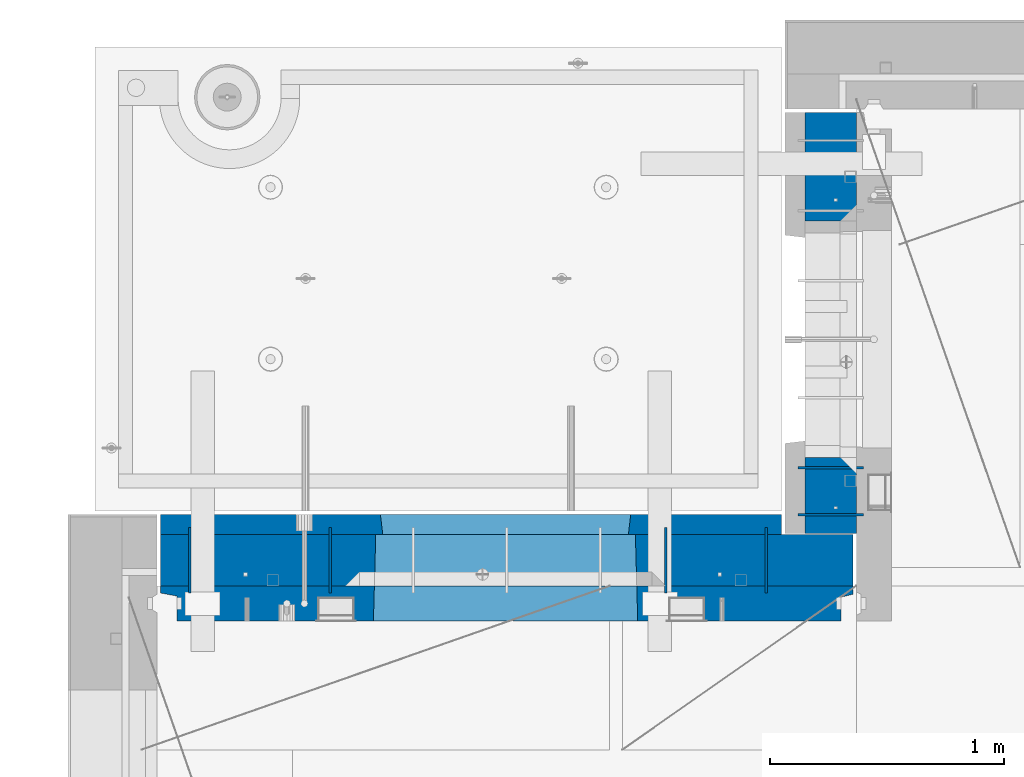
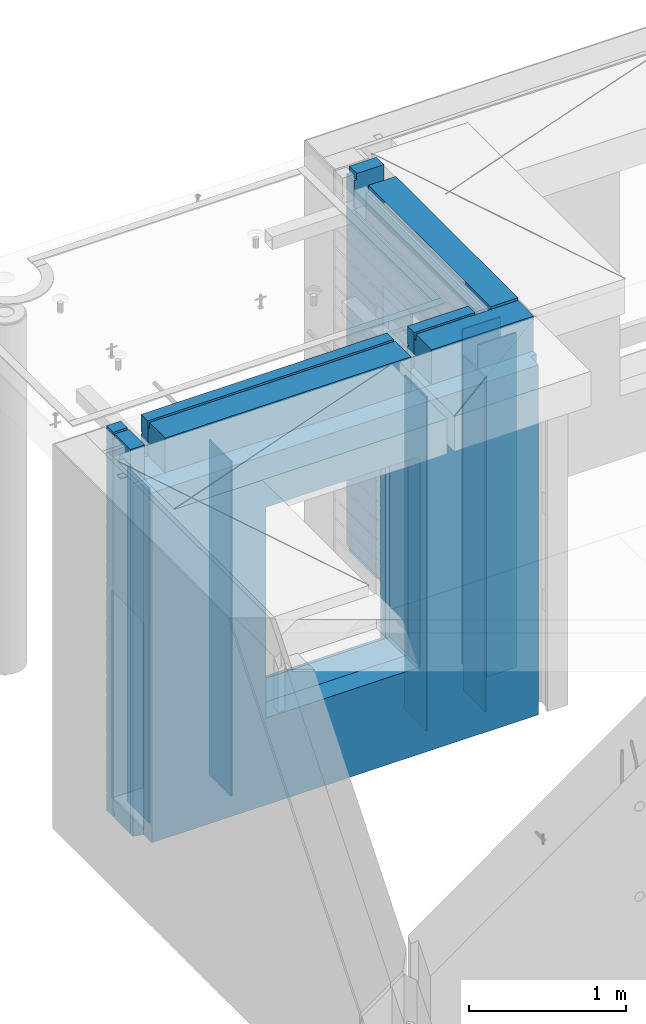
# One storey, part 227 of 341: 10 walls, 2 elements without a shape of their own.
"""IFC2X3 building model written with IfcOpenShell, lengths in millimetres."""

from ifc_helpers import new_model, si_unit, frame, origin_with_axes, place, context, subcontext, project, spatial, faceted_brep, material, type_object, element, aggregate, save


model = new_model("IFC2X3")

# Units and contexts
model_context = context("Model", 3, precision=1e-05, world=origin_with_axes())
body_context = subcontext(model_context, "Body", "Model", "MODEL_VIEW")
ifc_project = project(units=[si_unit("LENGTHUNIT", "METRE", prefix="MILLI"), si_unit("AREAUNIT", "SQUARE_METRE"), si_unit("VOLUMEUNIT", "CUBIC_METRE"), si_unit("MASSUNIT", "GRAM", prefix="KILO"), si_unit("TIMEUNIT", "SECOND"), si_unit("PLANEANGLEUNIT", "RADIAN"), si_unit("SOLIDANGLEUNIT", "STERADIAN"), si_unit("THERMODYNAMICTEMPERATUREUNIT", "DEGREE_CELSIUS"), si_unit("LUMINOUSINTENSITYUNIT", "LUMEN")], contexts=[model_context])

# Site, building, storey
site_placement = place(None, origin_with_axes())
site = spatial("IfcSite", under=ifc_project, at=site_placement, CompositionType="ELEMENT")
building_placement = place(site_placement, origin_with_axes())
building = spatial("IfcBuilding", under=site, at=building_placement, CompositionType="ELEMENT")
storey_placement = place(building_placement, origin_with_axes())
storey = spatial("IfcBuildingStorey", under=building, at=storey_placement, Name="5", CompositionType="ELEMENT", Elevation=0.0)

# Assembly, wall
assembly_1_placement = place(storey_placement, origin_with_axes())
assembly_1 = element("IfcElementAssembly", 1, at=assembly_1_placement, inside=storey, AssemblyPlace="NOTDEFINED", PredefinedType="REINFORCEMENT_UNIT")
ifc_material_1 = material(Name="Undefined")
wall_type_1 = type_object("IfcWallType", PredefinedType="NOTDEFINED")
wall_1_placement = place(assembly_1_placement, frame((10605.0002441406, 20549.9951872276, 95115.0), z_axis=(0.0, 0.0, 1.0), x_axis=(0.0, 1.0, 0.0)))
wall_1 = element("IfcWall", 2, at=wall_1_placement, type_object=wall_type_1, material=ifc_material_1, Name="(PD)", context=body_context, shape_type="Brep", body=[
    faceted_brep([(0.0, 5.0, -1300.0), (0.0, 5.0, 1300.0), (280.0, 5.0, 1300.0), (280.0, 5.0, -1300.0), (0.0, -5.0, 1300.0), (280.0, -5.0, 1300.0), (0.0, -5.0, -1300.0), (280.0, -5.0, -1300.0)], [[[0, 1, 2, 3]], [[1, 4, 5, 2]], [[4, 6, 7, 5]], [[6, 0, 3, 7]], [[5, 7, 3, 2]], [[6, 4, 1, 0]]]),
])

assembly_2_placement = place(storey_placement, origin_with_axes())
assembly_2 = element("IfcElementAssembly", 3, at=assembly_2_placement, inside=storey, AssemblyPlace="NOTDEFINED", PredefinedType="REINFORCEMENT_UNIT")
wall_2_placement = place(assembly_2_placement, frame((11020.0, 20885.0002441406, 95115.0), z_axis=(0.0, 0.0, 1.0), x_axis=(-1.0, 3.00000001838171e-08, 0.0)))
wall_2 = element("IfcWall", 4, at=wall_2_placement, type_object=wall_type_1, material=ifc_material_1, Name="(PD)", context=body_context, shape_type="Brep", body=[
    faceted_brep([(0.0, 5.0, -1300.0), (0.0, 5.0, 1300.0), (280.0, 5.0, 1300.0), (280.0, 5.0, -1300.0), (0.0, -5.0, 1300.0), (280.0, -5.0, 1300.0), (0.0, -5.0, -1300.0), (280.0, -5.0, -1300.0)], [[[0, 1, 2, 3]], [[1, 4, 5, 2]], [[4, 6, 7, 5]], [[6, 0, 3, 7]], [[5, 7, 3, 2]], [[6, 4, 1, 0]]]),
])

# Wall
wall_3_placement = place(assembly_1_placement, frame((8140.00024414063, 20549.9951872276, 95115.0), z_axis=(0.0, 0.0, 1.0), x_axis=(0.0, 1.0, 0.0)))
wall_3 = element("IfcWall", 5, at=wall_3_placement, type_object=wall_type_1, material=ifc_material_1, Name="(PD)", context=body_context, shape_type="Brep", body=[
    faceted_brep([(0.0, 5.0, -1300.0), (0.0, 5.0, 1300.0), (280.0, 5.0, 1300.0), (280.0, 5.0, -1300.0), (0.0, -5.0, 1300.0), (280.0, -5.0, 1300.0), (0.0, -5.0, -1300.0), (280.0, -5.0, -1300.0)], [[[0, 1, 2, 3]], [[1, 4, 5, 2]], [[4, 6, 7, 5]], [[6, 0, 3, 7]], [[5, 7, 3, 2]], [[6, 4, 1, 0]]]),
])

wall_4_placement = place(assembly_1_placement, frame((8740.00024414063, 20549.9951872276, 95115.0), z_axis=(0.0, 0.0, 1.0), x_axis=(0.0, 1.0, 0.0)))
wall_4 = element("IfcWall", 6, at=wall_4_placement, type_object=wall_type_1, material=ifc_material_1, Name="(PD)", context=body_context, shape_type="Brep", body=[
    faceted_brep([(0.0, 5.0, -1300.0), (0.0, 5.0, 1300.0), (280.0, 5.0, 1300.0), (280.0, 5.0, -1300.0), (0.0, -5.0, 1300.0), (280.0, -5.0, 1300.0), (0.0, -5.0, -1300.0), (280.0, -5.0, -1300.0)], [[[0, 1, 2, 3]], [[1, 4, 5, 2]], [[4, 6, 7, 5]], [[6, 0, 3, 7]], [[5, 7, 3, 2]], [[6, 4, 1, 0]]]),
])

wall_5_placement = place(assembly_1_placement, frame((10175.0002441406, 20549.9951872276, 95115.0), z_axis=(0.0, 0.0, 1.0), x_axis=(0.0, 1.0, 0.0)))
wall_5 = element("IfcWall", 7, at=wall_5_placement, type_object=wall_type_1, material=ifc_material_1, Name="(PD)", context=body_context, shape_type="Brep", body=[
    faceted_brep([(0.0, 5.0, -1300.0), (0.0, 5.0, 1300.0), (280.0, 5.0, 1300.0), (280.0, 5.0, -1300.0), (0.0, -5.0, 1300.0), (280.0, -5.0, 1300.0), (0.0, -5.0, -1300.0), (280.0, -5.0, -1300.0)], [[[0, 1, 2, 3]], [[1, 4, 5, 2]], [[4, 6, 7, 5]], [[6, 0, 3, 7]], [[5, 7, 3, 2]], [[6, 4, 1, 0]]]),
])

wall_6_placement = place(assembly_2_placement, frame((11020.0, 21085.0002441406, 95115.0), z_axis=(0.0, 0.0, 1.0), x_axis=(-1.0, 3.00000001838171e-08, 0.0)))
wall_6 = element("IfcWall", 8, at=wall_6_placement, type_object=wall_type_1, material=ifc_material_1, Name="(PD)", context=body_context, shape_type="Brep", body=[
    faceted_brep([(0.0, 5.0, -1300.0), (0.0, 5.0, 1300.0), (280.0, 5.0, 1300.0), (280.0, 5.0, -1300.0), (0.0, -5.0, 1300.0), (280.0, -5.0, 1300.0), (0.0, -5.0, -1300.0), (280.0, -5.0, -1300.0)], [[[0, 1, 2, 3]], [[1, 4, 5, 2]], [[4, 6, 7, 5]], [[6, 0, 3, 7]], [[5, 7, 3, 2]], [[6, 4, 1, 0]]]),
])

ifc_material_2 = material(Name="COS5gt")
wall_type_2 = type_object("IfcWallType", PredefinedType="NOTDEFINED")
wall_7_placement = place(assembly_1_placement, frame((8000.0, 20689.9951872276, 95247.5), z_axis=(0.0, 0.0, 1.0), x_axis=(1.0, 0.0, 0.0)))
wall_7 = element("IfcWall", 9, at=wall_7_placement, type_object=wall_type_2, material=ifc_material_2, context=body_context, shape_type="Brep", body=[
    faceted_brep([(15.0, 110.0, 1442.5), (15.0, 90.0, 1442.5), (119.999999999998, 90.0, 1442.5), (119.999999999998, 110.0, 1442.5), (15.0, 90.0, 1492.5), (119.999999999998, 90.0, 1492.5), (15.0, -110.0, 1492.5), (119.999999999998, -110.0, 1492.5), (119.999999999998, -110.0, 1222.5), (119.999999999998, 110.0, 1222.5), (269.999999999998, -110.0, 1222.5), (269.999999999998, 110.0, 1222.5), (269.999999999998, 110.0, 1442.5), (269.999999999998, 90.0, 1442.5), (2075.0, 90.0, 1442.5), (2075.0, 110.0, 1442.5), (269.999999999998, 90.0, 1492.5), (2075.0, 90.0, 1492.5), (269.999999999998, -110.0, 1492.5), (2075.0, -110.0, 1492.5), (2075.0, -110.000000000004, 1222.5), (2075.0, 109.999999999996, 1222.5), (2225.0, -110.000000000004, 1222.5), (2225.0, 109.999999999996, 1222.5), (2975.0, -110.0, 1492.5), (2975.0, 90.0, 1492.5), (2225.0, 90.0, 1492.5), (2225.0, -110.0, 1492.5), (2975.0, -110.0, -1492.5), (15.0, -110.0, -1492.5), (15.0, 90.0, -1492.5), (2975.0, 90.0, -1492.5), (2975.0, 110.0, 1442.5), (2975.0, 90.0, 1442.5), (2975.0, 90.0, -1442.5), (2975.0, 110.0, -1442.5), (2225.0, 110.0, 1442.5), (2225.0, 90.0, 1442.5), (929.055290664681, -110.000000000004, -813.445945945947), (929.055290664681, -110.000000000004, 813.445945945947), (2050.94718255657, -110.000000000004, 813.445945945947), (2050.94718255657, -110.000000000004, -813.445945945947), (935.001236610628, 110.0, -802.5), (935.001236610628, 110.0, 807.5), (935.001236610628, 110.0, -807.5), (2045.00123661063, 110.0, -807.5), (2015.00123661063, 110.0, -807.5), (965.001236610628, 110.0, -807.5), (2045.00123661063, 110.0, 807.5), (2045.00123661063, 110.0, -802.5), (15.0, 110.0, -1442.5), (15.0, 90.0, -1442.5)], [[[0, 1, 2, 3]], [[1, 4, 5, 2]], [[4, 6, 7, 5]], [[3, 2, 5, 7, 8, 9]], [[9, 8, 10, 11]], [[12, 13, 14, 15]], [[13, 16, 17, 14]], [[12, 11, 10, 18, 16, 13]], [[16, 18, 19, 17]], [[15, 14, 17, 19, 20, 21]], [[21, 20, 22, 23]], [[24, 25, 26, 27]], [[28, 29, 30, 31]], [[32, 33, 25, 24, 28, 31, 34, 35]], [[33, 32, 36, 37]], [[25, 33, 37, 26]], [[36, 23, 22, 27, 26, 37]], [[20, 19, 18, 10, 8, 7, 6, 29, 28, 24, 27, 22], [38, 39, 40, 41]], [[42, 43, 39, 38, 44]], [[41, 45, 46, 47, 44, 38]], [[40, 48, 49, 45, 41]], [[39, 43, 48, 40]], [[32, 35, 50, 0, 3, 9, 11, 12, 15, 21, 23, 36], [42, 44, 47, 46, 45, 49, 48, 43]], [[30, 29, 6, 4, 1, 0, 50, 51]], [[35, 34, 51, 50]], [[31, 30, 51, 34]]]),
])

wall_8_placement = place(assembly_2_placement, frame((10880.0, 20805.0, 95247.5), z_axis=(0.0, 0.0, 1.0), x_axis=(0.0, 1.0, 0.0)))
wall_8 = element("IfcWall", 10, at=wall_8_placement, type_object=wall_type_2, material=ifc_material_2, context=body_context, shape_type="Brep", body=[
    faceted_brep([(1800.0, -110.0, 1492.5), (1800.0, 90.0, 1492.5), (1705.0, 90.0, 1492.5), (1705.0, -110.0, 1492.5), (1800.0, 90.0, 1442.5), (1800.0, 110.0, 1442.5), (1705.0, 110.0, 1442.5), (1705.0, 90.0, 1442.5), (0.0, 110.0, 1442.5), (0.0, 90.0, 1442.5), (1555.0, 90.0, 1442.5), (1555.0, 110.0, 1442.5), (0.0, -110.0, -1492.5), (0.0, 90.0, -1492.5), (325.000271651108, 90.0, -1492.5), (325.000271651108, -110.0, -1492.5), (0.0, 90.0, -1442.5), (325.000271651108, 90.0, -1442.5), (0.0, -110.0, 1492.5), (0.0, 90.0, 1492.5), (0.0, 110.0, -1442.5), (325.000271651108, 110.0, -1442.5), (325.000271651108, 110.0, 857.5), (325.000271651108, -110.0, 857.5), (1335.00027165111, 110.0, 857.5), (1335.00027165111, -110.0, 857.5), (1555.0, 110.0, 1222.5), (1705.0, 110.0, 1222.5), (1800.0, 110.0, -1442.5), (1335.00027165111, 110.0, -1442.5), (1800.0, 90.0, -1442.5), (1800.0, 90.0, -1492.5), (1335.00027165111, 90.0, -1492.5), (1335.00027165111, 90.0, -1442.5), (1800.0, -110.0, -1492.5), (1335.00027165111, -110.0, -1492.5), (1705.0, -110.0, 1222.5), (1555.0, -110.0, 1222.5), (1555.0, -110.0, 1492.5), (1555.0, 90.0, 1492.5)], [[[0, 1, 2, 3]], [[4, 5, 6, 7]], [[8, 9, 10, 11]], [[12, 13, 14, 15]], [[13, 16, 17, 14]], [[13, 12, 18, 19, 9, 8, 20, 16]], [[16, 20, 21, 17]], [[15, 14, 17, 21, 22, 23]], [[23, 22, 24, 25]], [[21, 20, 8, 11, 26, 27, 6, 5, 28, 29, 24, 22]], [[30, 31, 32, 33]], [[28, 30, 33, 29]], [[5, 4, 1, 0, 34, 31, 30, 28]], [[31, 34, 35, 32]], [[25, 24, 29, 33, 32, 35]], [[34, 0, 3, 36, 37, 38, 18, 12, 15, 23, 25, 35]], [[19, 18, 38, 39]], [[9, 19, 39, 10]], [[38, 37, 26, 11, 10, 39]], [[36, 27, 26, 37]], [[3, 2, 7, 6, 27, 36]], [[1, 4, 7, 2]]]),
])

aggregate(assembly_2, [wall_2, wall_6, wall_8])

ifc_material_3 = material(Name="CONCRETE/C30/37")
wall_type_3 = type_object("IfcWallType", PredefinedType="NOTDEFINED")
wall_9_placement = place(assembly_1_placement, frame((8000.0, 20842.4951872276, 95247.5), z_axis=(0.0, 0.0, 1.0), x_axis=(1.0, 0.0, 0.0)))
wall_9 = element("IfcWall", 11, at=wall_9_placement, type_object=wall_type_3, material=ifc_material_3, context=body_context, shape_type="Brep", body=[
    faceted_brep([(2670.0, -42.5, 1492.5), (2670.0, 42.5, 1492.5), (2225.0, 42.5, 1492.5), (2225.0, -42.5, 1492.5), (2670.0, 42.4999992431622, 1356.99999988925), (2225.0, 42.4999993700148, 1356.99999988925), (2670.0, 32.4999991126933, 1355.00000040043), (2670.0, 32.4999992506928, 1344.9999999992), (2225.0, 32.4999992506928, 1344.9999999992), (2225.0, 32.4999991126933, 1355.00000040043), (2670.0, 42.4999996036859, 1342.99999994476), (2225.0, 42.4999996701117, 1342.99999994476), (2670.0, 42.4999993831079, 892.999999944761), (15.0, 42.5, 892.999999944761), (15.0, 32.4999992506928, 894.9999999992), (2670.0, 32.4999992506928, 894.9999999992), (15.0, 32.4999991126933, 905.000000400425), (2670.0, 32.4999991126933, 905.000000400425), (2670.0, 42.4999992431622, 906.999999889245), (15.0, 42.5, 906.999999889245), (15.0, 42.5, 1042.99999994476), (2670.0, 42.4999994189602, 1042.99999994476), (15.0, 32.4999992506928, 1044.9999999992), (2670.0, 32.4999992506928, 1044.9999999992), (15.0, 32.4999991126933, 1055.00000040043), (2670.0, 32.4999991126933, 1055.00000040043), (2670.0, 42.4999992431622, 1056.99999988925), (15.0, 42.5, 1056.99999988925), (15.0, 42.5, 1192.99999994476), (2670.0, 42.4999994795107, 1192.99999994476), (15.0000000000009, 32.4999992506928, 1194.9999999992), (2670.0, 32.4999992506928, 1194.9999999992), (15.0000000000009, 32.4999991126933, 1205.00000040043), (2670.0, 32.4999991126933, 1205.00000040043), (2670.0, 42.4999992431622, 1206.99999988925), (15.0, 42.5, 1206.99999988925), (15.0, 32.4999992506928, 1344.9999999992), (15.0, 32.4999991126933, 1355.00000040043), (119.999999999998, 32.4999991126933, 1355.00000040043), (119.999999999998, 32.4999992506928, 1344.9999999992), (15.0, 42.5, 1342.99999994476), (119.999999999998, 42.4999999843276, 1342.99999994476), (269.999999999998, 32.4999992506928, 1344.9999999992), (269.999999999998, 32.4999991126933, 1355.00000040043), (2075.0, 32.4999991126933, 1355.00000040043), (2075.0, 32.4999992506928, 1344.9999999992), (269.999999999998, 42.4999999619358, 1342.99999994476), (2075.0, 42.4999996925035, 1342.99999994476), (119.999999999998, 42.4999999076099, 1222.5), (269.999999999998, 42.4999998750354, 1222.5), (2075.0, 42.4999994593163, 1222.5), (2225.0, 42.4999994264763, 1222.5), (119.999999999998, -42.5, 1222.5), (269.999999999998, -42.5, 1222.5), (269.999999999998, 42.5, 1492.5), (269.999999999998, 42.4999999273095, 1356.99999988925), (269.999999999998, -42.5, 1492.5), (2075.0, -42.5, 1492.5), (2075.0, 42.5, 1492.5), (2075.0, 42.4999994127757, 1356.99999988925), (2075.0, -42.5000000000036, 1222.5), (2225.0, -42.5000000000036, 1222.5), (2670.0, -42.5, -1492.5), (2670.0, 42.5, -1492.5), (2670.0, 42.5, -1357.00000005524), (2670.0, 32.4999992506928, -1355.0000000008), (2670.0, 32.4999991126933, -1344.99999959957), (2670.0, 42.4999992431622, -1343.00000011075), (2670.0, 42.4999992794619, -1207.00000005524), (2670.0, 32.4999992506928, -1205.0000000008), (2670.0, 32.4999991126933, -1194.99999959957), (2670.0, 42.4999992431622, -1193.00000011075), (2670.0, 42.4999992814919, -1057.00000005524), (2670.0, 32.4999992506928, -1055.0000000008), (2670.0, 32.4999991126933, -1044.99999959957), (2670.0, 42.4999992431622, -1043.00000011075), (2670.0, 42.4999992837584, -907.000000055239), (2670.0, 32.4999992506928, -905.0000000008), (2670.0, 32.4999991126933, -894.999999599575), (2670.0, 42.4999992431622, -893.000000110755), (2670.0, 42.4999992863086, -757.000000055239), (2670.0, 32.4999992506928, -755.0000000008), (2670.0, 32.4999991126933, -744.999999599575), (2670.0, 42.4999992431622, -743.000000110755), (2670.0, 42.4999992892044, -607.000000055239), (2670.0, 32.4999992506928, -605.0000000008), (2670.0, 32.4999991126933, -594.999999599575), (2670.0, 42.4999992431622, -593.000000110755), (2670.0, 42.4999992925186, -457.000000055239), (2670.0, 32.4999992506928, -455.0000000008), (2670.0, 32.4999991126933, -444.999999599575), (2670.0, 42.4999992431622, -443.000000110755), (2670.0, 42.4999992963421, -307.000000055239), (2670.0, 32.4999992506928, -305.0000000008), (2670.0, 32.4999991126933, -294.999999599575), (2670.0, 42.4999992431622, -293.000000110755), (2670.0, 42.4999993008096, -157.000000055239), (2670.0, 32.4999992506928, -155.0000000008), (2670.0, 32.4999991126933, -144.999999599575), (2670.0, 42.4999992431622, -143.000000110755), (2670.0, 42.4999993060956, -7.00000005523907), (2670.0, 32.4999992506928, -5.00000000080036), (2670.0, 32.4999991126933, 5.00000040042505), (2670.0, 42.4999992431622, 6.99999988924537), (2670.0, 42.4999993124511, 142.999999944761), (2670.0, 32.4999992506928, 144.9999999992), (2670.0, 32.4999991126933, 155.000000400425), (2670.0, 42.4999992431622, 156.999999889245), (2670.0, 42.4999993202327, 292.999999944761), (2670.0, 32.4999992506928, 294.9999999992), (2670.0, 32.4999991126933, 305.000000400425), (2670.0, 42.4999992431622, 306.999999889245), (2670.0, 42.4999993299862, 442.999999944761), (2670.0, 32.4999992506928, 444.9999999992), (2670.0, 32.4999991126933, 455.000000400425), (2670.0, 42.4999992431622, 456.999999889245), (2670.0, 42.4999993425627, 592.999999944761), (2670.0, 32.4999992506928, 594.9999999992), (2670.0, 32.4999991126933, 605.000000400425), (2670.0, 42.4999992431622, 606.999999889245), (2670.0, 42.4999993594029, 742.999999944761), (2670.0, 32.4999992506928, 744.9999999992), (2670.0, 32.4999991126933, 755.000000400425), (2670.0, 42.4999992431622, 756.999999889245), (15.0, -42.5, -1492.5), (15.0, 42.5, -1492.5), (15.0, 42.5, -1357.00000005524), (15.0, 32.4999992506928, -1355.0000000008), (15.0, 32.4999991126933, -1344.99999959957), (15.0, 42.5, -1343.00000011075), (15.0, 42.5, -1207.00000005524), (15.0, 32.4999992506928, -1205.0000000008), (15.0, 32.4999991126933, -1194.99999959957), (15.0, 42.5, -1193.00000011075), (15.0, 42.5, -1057.00000005524), (15.0, 32.4999992506928, -1055.0000000008), (15.0, 32.4999991126933, -1044.99999959957), (15.0, 42.5, -1043.00000011075), (15.0, 42.5, -907.000000055239), (15.0000000000009, 32.4999992506928, -905.0000000008), (15.0000000000009, 32.4999991126933, -894.999999599575), (15.0, 42.5, -893.000000110755), (15.0, 32.4999991126933, 755.000000400425), (15.0, 42.5, 756.999999889245), (955.001236610628, 42.499999732041, 756.999999889245), (956.177707303252, 32.4999991126933, 755.000000400425), (15.0, 32.4999992506928, 744.9999999992), (956.177707287017, 32.4999992506928, 744.9999999992), (15.0, 42.5, 742.999999944761), (955.001236610628, 42.4999997731975, 742.999999944761), (15.0, 42.5, 606.999999889245), (955.001236610628, 42.499999732041, 606.999999889245), (15.0, 32.4999991126933, 605.000000400425), (956.177707303252, 32.4999991126933, 605.000000400425), (15.0, 32.4999992506928, 594.9999999992), (956.177707287017, 32.4999992506928, 594.9999999992), (15.0, 42.5, 592.999999944761), (955.001236610628, 42.4999997672348, 592.999999944761), (15.0, 42.5, 456.999999889245), (955.001236610628, 42.499999732041, 456.999999889245), (15.0, 32.4999991126933, 455.000000400425), (956.177707303252, 32.4999991126933, 455.000000400425), (15.0, 32.4999992506928, 444.9999999992), (956.177707287017, 32.4999992506928, 444.9999999992), (15.0, 42.5, 442.999999944761), (955.001236610628, 42.499999762782, 442.999999944761), (15.0, 42.5, 306.999999889245), (955.001236610628, 42.499999732041, 306.999999889245), (15.0, 32.4999991126933, 305.000000400425), (956.177707303252, 32.4999991126933, 305.000000400425), (15.0, 32.4999992506928, 294.9999999992), (956.177707287017, 32.4999992506928, 294.9999999992), (15.0, 42.5, 292.999999944761), (955.001236610628, 42.4999997593295, 292.999999944761), (15.0, 42.5, 156.999999889245), (955.001236610628, 42.499999732041, 156.999999889245), (15.0000000000009, 32.4999991126933, 155.000000400425), (956.177707303254, 32.4999991126933, 155.000000400425), (15.0000000000009, 32.4999992506928, 144.9999999992), (956.177707287017, 32.4999992506928, 144.9999999992), (15.0, 42.5, 142.999999944761), (955.001236610628, 42.4999997565719, 142.999999944761), (15.0, 42.5, 6.99999988924537), (955.001236610628, 42.499999732041, 6.99999988924537), (14.9999999999991, 32.4999991126933, 5.00000040042505), (956.177707303254, 32.4999991126933, 5.00000040042505), (14.9999999999991, 32.4999992506928, -5.00000000080036), (956.177707287017, 32.4999992506928, -5.00000000080036), (15.0, 42.5, -7.00000005523907), (955.001236610628, 42.4999997543237, -7.00000005523907), (15.0, 42.5, -143.000000110755), (955.001236610628, 42.499999732041, -143.000000110755), (15.0000000000009, 32.4999991126933, -144.999999599575), (956.177707303254, 32.4999991126933, -144.999999599575), (15.0000000000009, 32.4999992506928, -155.0000000008), (956.177707287017, 32.4999992506928, -155.0000000008), (15.0, 42.5, -157.000000055239), (955.001236610628, 42.4999997524537, -157.000000055239), (15.0, 42.5, -293.000000110755), (955.001236610628, 42.499999732041, -293.000000110755), (15.0, 32.4999991126933, -294.999999599575), (956.177707303252, 32.4999991126933, -294.999999599575), (15.0, 32.4999992506928, -305.0000000008), (956.177707287017, 32.4999992506928, -305.0000000008), (15.0, 42.5, -307.000000055239), (955.001236610628, 42.4999997508712, -307.000000055239), (15.0, 42.5, -443.000000110755), (955.001236610628, 42.499999732041, -443.000000110755), (15.0000000000009, 32.4999991126933, -444.999999599575), (956.177707303254, 32.4999991126933, -444.999999599575), (15.0000000000009, 32.4999992506928, -455.0000000008), (956.177707287017, 32.4999992506928, -455.0000000008), (15.0, 42.5, -457.000000055239), (955.001236610628, 42.4999997495179, -457.000000055239), (15.0, 42.5, -593.000000110755), (955.001236610628, 42.499999732041, -593.000000110755), (15.0, 32.4999991126933, -594.999999599575), (956.177707303252, 32.4999991126933, -594.999999599575), (15.0, 32.4999992506928, -605.0000000008), (956.177707287017, 32.4999992506928, -605.0000000008), (15.0, 42.5, -607.000000055239), (955.001236610628, 42.4999997483428, -607.000000055239), (15.0, 42.5, -743.000000110755), (955.001236610628, 42.499999732041, -743.000000110755), (15.0, 32.4999991126933, -744.999999599575), (956.177707303252, 32.4999991126933, -744.999999599575), (15.0, 32.4999992506928, -755.0000000008), (956.177707287017, 32.4999992506928, -755.0000000008), (15.0, 42.5, -757.000000055239), (955.001236610628, 42.4999997473169, -757.000000055239), (955.001236610628, 42.5, -857.5), (965.001236610628, -42.5, -807.5), (2015.00123661063, -42.5, -807.5), (2025.00123661063, 42.5, -857.5), (2025.00123661063, 42.499999459691, -757.000000055239), (2023.82476593424, 32.4999992506928, -755.0000000008), (2023.824765918, 32.4999991126933, -744.999999599575), (2025.00123661063, 42.4999994270256, -743.000000110755), (2025.00123661063, 42.4999994618847, -607.000000055239), (2023.82476593424, 32.4999992506928, -605.0000000008), (2023.824765918, 32.4999991126933, -594.999999599575), (2025.00123661063, 42.4999994270256, -593.000000110755), (2025.00123661063, 42.4999994643913, -457.000000055239), (2023.82476593424, 32.4999992506928, -455.0000000008), (2023.824765918, 32.4999991126933, -444.999999599575), (2025.00123661063, 42.4999994270256, -443.000000110755), (2025.00123661063, 42.4999994672871, -307.000000055239), (2023.82476593424, 32.4999992506928, -305.0000000008), (2023.824765918, 32.4999991126933, -294.999999599575), (2025.00123661063, 42.4999994270256, -293.000000110755), (2025.00123661063, 42.4999994706704, -157.000000055239), (2023.82476593424, 32.4999992506928, -155.0000000008), (2023.824765918, 32.4999991126933, -144.999999599575), (2025.00123661063, 42.4999994270256, -143.000000110755), (2025.00123661063, 42.4999994746722, -7.00000005523907), (2023.82476593424, 32.4999992506928, -5.00000000080036), (2023.824765918, 32.4999991126933, 5.00000040042505), (2025.00123661063, 42.4999994270256, 6.99999988924537), (2025.00123661063, 42.4999994794816, 142.999999944761), (2023.82476593424, 32.4999992506928, 144.9999999992), (2023.824765918, 32.4999991126933, 155.000000400425), (2025.00123661063, 42.4999994270256, 156.999999889245), (2025.00123661063, 42.4999994853752, 292.999999944761), (2023.82476593424, 32.4999992506928, 294.9999999992), (2023.824765918, 32.4999991126933, 305.000000400425), (2025.00123661063, 42.4999994270256, 306.999999889245), (2025.00123661063, 42.4999994927566, 442.999999944761), (2023.82476593424, 32.4999992506928, 444.9999999992), (2023.824765918, 32.4999991126933, 455.000000400425), (2025.00123661063, 42.4999994270256, 456.999999889245), (2025.00123661063, 42.4999995022772, 592.999999944761), (2023.82476593424, 32.4999992506928, 594.9999999992), (2023.824765918, 32.4999991126933, 605.000000400425), (2025.00123661063, 42.4999994270256, 606.999999889245), (2025.00123661063, 42.4999995150283, 742.999999944761), (2023.82476593424, 32.4999992506928, 744.9999999992), (2023.824765918, 32.4999991126933, 755.000000400425), (2025.00123661063, 42.4999994270256, 756.999999889245), (965.001236610628, 42.5, 782.5), (955.001236610628, 42.5, 782.5), (2025.00123661063, 42.5, 782.5), (2015.00123661063, 42.5, 782.5), (965.001236610628, -42.5, 782.5), (965.001236610628, -42.5, 787.5), (2015.00123661063, -42.5, 787.5), (2015.00123661063, -42.5, 782.5), (119.999999999998, -42.5, 1492.5), (15.0, -42.5, 1492.5), (15.0, 42.5, 1492.5), (119.999999999998, 42.5, 1492.5), (15.0, 42.5, 1356.99999988925), (119.999999999998, 42.4999999700703, 1356.99999988925)], [[[0, 1, 2, 3]], [[1, 4, 5, 2]], [[6, 7, 8, 9]], [[7, 10, 11, 8]], [[12, 13, 14, 15]], [[15, 14, 16, 17]], [[18, 17, 16, 19]], [[18, 19, 20, 21]], [[21, 20, 22, 23]], [[23, 22, 24, 25]], [[26, 25, 24, 27]], [[26, 27, 28, 29]], [[29, 28, 30, 31]], [[31, 30, 32, 33]], [[34, 33, 32, 35]], [[36, 37, 38, 39]], [[40, 36, 39, 41]], [[42, 43, 44, 45]], [[46, 42, 45, 47]], [[10, 34, 35, 40, 41, 48, 49, 46, 47, 50, 51, 11]], [[48, 52, 53, 49]], [[54, 55, 43, 42, 46, 49, 53, 56]], [[54, 56, 57, 58]], [[55, 54, 58, 59]], [[43, 55, 59, 44]], [[58, 57, 60, 50, 47, 45, 44, 59]], [[50, 60, 61, 51]], [[2, 5, 9, 8, 11, 51, 61, 3]], [[4, 6, 9, 5]], [[1, 0, 62, 63, 64, 65, 66, 67, 68, 69, 70, 71, 72, 73, 74, 75, 76, 77, 78, 79, 80, 81, 82, 83, 84, 85, 86, 87, 88, 89, 90, 91, 92, 93, 94, 95, 96, 97, 98, 99, 100, 101, 102, 103, 104, 105, 106, 107, 108, 109, 110, 111, 112, 113, 114, 115, 116, 117, 118, 119, 120, 121, 122, 123, 12, 15, 17, 18, 21, 23, 25, 26, 29, 31, 33, 34, 10, 7, 6, 4]], [[124, 125, 63, 62]], [[63, 125, 126, 64]], [[64, 126, 127, 65]], [[65, 127, 128, 66]], [[67, 66, 128, 129]], [[67, 129, 130, 68]], [[68, 130, 131, 69]], [[69, 131, 132, 70]], [[71, 70, 132, 133]], [[71, 133, 134, 72]], [[72, 134, 135, 73]], [[73, 135, 136, 74]], [[75, 74, 136, 137]], [[75, 137, 138, 76]], [[76, 138, 139, 77]], [[77, 139, 140, 78]], [[79, 78, 140, 141]], [[142, 143, 144, 145]], [[146, 142, 145, 147]], [[148, 146, 147, 149]], [[150, 148, 149, 151]], [[152, 150, 151, 153]], [[154, 152, 153, 155]], [[156, 154, 155, 157]], [[158, 156, 157, 159]], [[160, 158, 159, 161]], [[162, 160, 161, 163]], [[164, 162, 163, 165]], [[166, 164, 165, 167]], [[168, 166, 167, 169]], [[170, 168, 169, 171]], [[172, 170, 171, 173]], [[174, 172, 173, 175]], [[176, 174, 175, 177]], [[178, 176, 177, 179]], [[180, 178, 179, 181]], [[182, 180, 181, 183]], [[184, 182, 183, 185]], [[186, 184, 185, 187]], [[188, 186, 187, 189]], [[190, 188, 189, 191]], [[192, 190, 191, 193]], [[194, 192, 193, 195]], [[196, 194, 195, 197]], [[198, 196, 197, 199]], [[200, 198, 199, 201]], [[202, 200, 201, 203]], [[204, 202, 203, 205]], [[206, 204, 205, 207]], [[208, 206, 207, 209]], [[210, 208, 209, 211]], [[212, 210, 211, 213]], [[214, 212, 213, 215]], [[216, 214, 215, 217]], [[218, 216, 217, 219]], [[220, 218, 219, 221]], [[222, 220, 221, 223]], [[224, 222, 223, 225]], [[226, 224, 225, 227]], [[228, 226, 227, 229]], [[230, 231, 232, 233]], [[80, 79, 141, 228, 229, 230, 233, 234]], [[81, 80, 234, 235]], [[82, 81, 235, 236]], [[83, 82, 236, 237]], [[84, 83, 237, 238]], [[85, 84, 238, 239]], [[86, 85, 239, 240]], [[87, 86, 240, 241]], [[88, 87, 241, 242]], [[89, 88, 242, 243]], [[90, 89, 243, 244]], [[91, 90, 244, 245]], [[92, 91, 245, 246]], [[93, 92, 246, 247]], [[94, 93, 247, 248]], [[95, 94, 248, 249]], [[96, 95, 249, 250]], [[97, 96, 250, 251]], [[98, 97, 251, 252]], [[99, 98, 252, 253]], [[100, 99, 253, 254]], [[101, 100, 254, 255]], [[102, 101, 255, 256]], [[103, 102, 256, 257]], [[104, 103, 257, 258]], [[105, 104, 258, 259]], [[106, 105, 259, 260]], [[107, 106, 260, 261]], [[108, 107, 261, 262]], [[109, 108, 262, 263]], [[110, 109, 263, 264]], [[111, 110, 264, 265]], [[112, 111, 265, 266]], [[113, 112, 266, 267]], [[114, 113, 267, 268]], [[115, 114, 268, 269]], [[116, 115, 269, 270]], [[117, 116, 270, 271]], [[118, 117, 271, 272]], [[119, 118, 272, 273]], [[120, 119, 273, 274]], [[121, 120, 274, 275]], [[122, 121, 275, 276]], [[123, 122, 276, 277]], [[278, 279, 144, 143, 13, 12, 123, 277, 280, 281]], [[282, 231, 230, 229, 227, 225, 223, 221, 219, 217, 215, 213, 211, 209, 207, 205, 203, 201, 199, 197, 195, 193, 191, 189, 187, 185, 183, 181, 179, 177, 175, 173, 171, 169, 167, 165, 163, 161, 159, 157, 155, 153, 151, 149, 147, 145, 144, 279, 283]], [[278, 281, 280, 284, 283, 279]], [[277, 276, 275, 274, 273, 272, 271, 270, 269, 268, 267, 266, 265, 264, 263, 262, 261, 260, 259, 258, 257, 256, 255, 254, 253, 252, 251, 250, 249, 248, 247, 246, 245, 244, 243, 242, 241, 240, 239, 238, 237, 236, 235, 234, 233, 232, 285, 284, 280]], [[60, 57, 56, 53, 52, 286, 287, 124, 62, 0, 3, 61], [232, 231, 282, 283, 284, 285]], [[288, 287, 286, 289]], [[36, 40, 35, 32, 30, 28, 27, 24, 22, 20, 19, 16, 14, 13, 143, 142, 146, 148, 150, 152, 154, 156, 158, 160, 162, 164, 166, 168, 170, 172, 174, 176, 178, 180, 182, 184, 186, 188, 190, 192, 194, 196, 198, 200, 202, 204, 206, 208, 210, 212, 214, 216, 218, 220, 222, 224, 226, 228, 141, 140, 139, 138, 137, 136, 135, 134, 133, 132, 131, 130, 129, 128, 127, 126, 125, 124, 287, 288, 290, 37]], [[37, 290, 291, 38]], [[289, 286, 52, 48, 41, 39, 38, 291]], [[290, 288, 289, 291]]]),
])

ifc_material_4 = material(Name="CONCRETE/C25/30")
wall_type_4 = type_object("IfcWallType", PredefinedType="NOTDEFINED")
wall_10_placement = place(assembly_1_placement, frame((8000.0, 20504.9951872276, 95112.5), z_axis=(0.0, 0.0, 1.0), x_axis=(1.0, 0.0, 0.0)))
wall_10 = element("IfcWall", 12, at=wall_10_placement, type_object=wall_type_4, material=ifc_material_4, context=body_context, shape_type="Brep", body=[
    faceted_brep([(2925.0, -75.0, 1357.5), (2925.0, -75.0, -1357.5), (2925.0, 27.0, -1357.5), (2925.0, 27.0, 1357.5), (2975.0, 75.0, 1357.5), (15.0, 75.0, 1357.5), (15.0, 45.0, 1357.5), (85.0, 32.0, 1357.5), (85.0, -75.0, 1357.5), (2975.0, 40.0, 1357.5), (85.0, 32.0, -1357.5), (85.0, -75.0, -1357.5), (15.0, 45.0, -1357.5), (15.0, 75.0, -1357.5), (2975.0, 75.0, -1357.5), (2975.0, 40.0, -1357.5), (925.001236610628, -75.0, 952.5), (929.055290664681, 75.0, 948.445945945947), (2050.94718255657, 75.0, 948.445945945947), (2055.00123661063, -75.0, 952.5), (929.055290664681, 75.0, -678.445945945947), (2050.94718255657, 75.0, -678.445945945947), (2055.00123661063, -75.0, -682.5), (925.001236610628, -75.0, -682.5)], [[[0, 1, 2, 3]], [[4, 5, 6, 7, 8, 0, 3, 9]], [[7, 10, 11, 8]], [[6, 12, 10, 7]], [[5, 13, 12, 6]], [[1, 11, 10, 12, 13, 14, 15, 2]], [[9, 3, 2, 15]], [[14, 4, 9, 15]], [[16, 17, 18, 19]], [[13, 5, 4, 14], [20, 21, 18, 17]], [[19, 18, 21, 22]], [[8, 11, 1, 0], [23, 16, 19, 22]], [[17, 16, 23, 20]], [[22, 21, 20, 23]]]),
])

aggregate(assembly_1, [wall_1, wall_3, wall_4, wall_5, wall_9, wall_7, wall_10])

save(model, "model.ifc")
